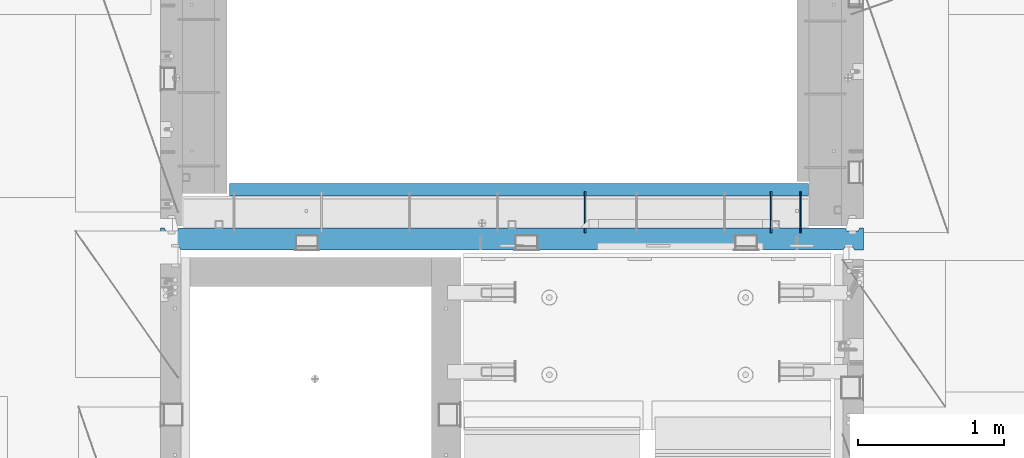
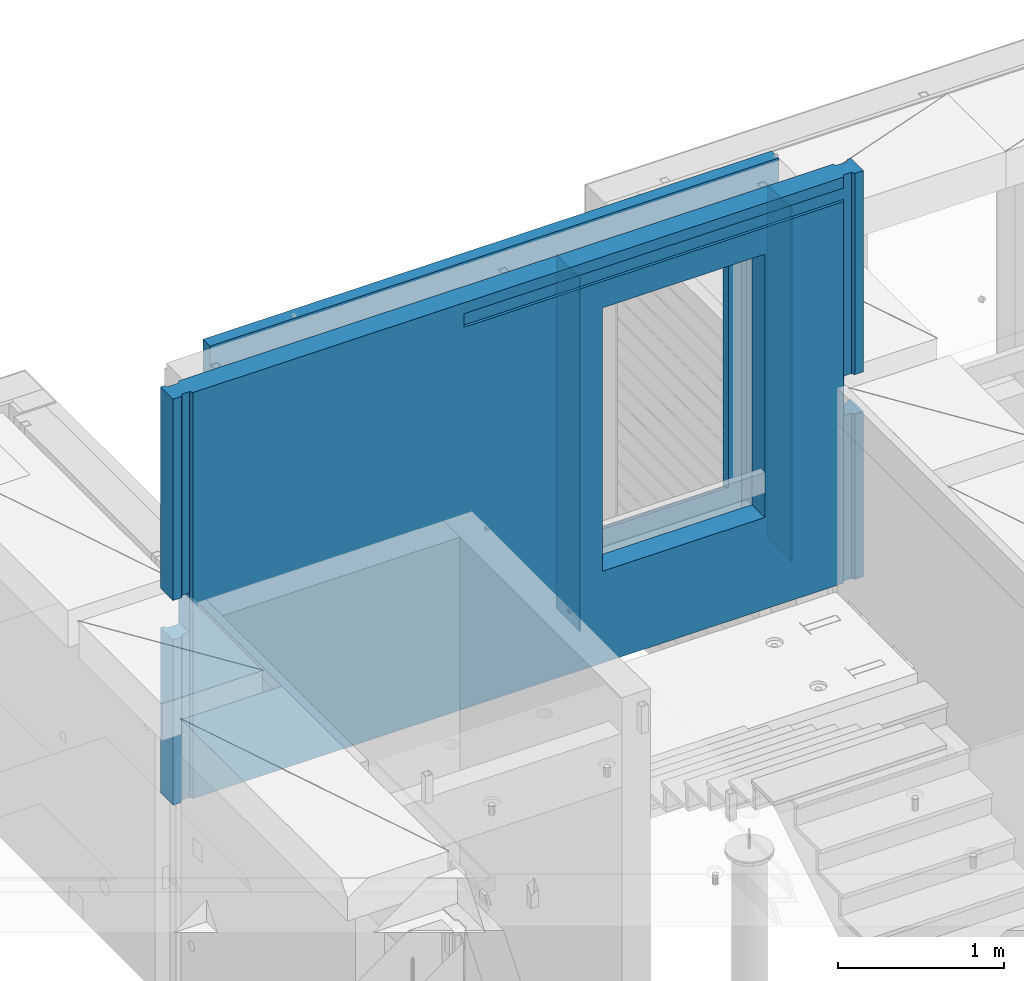
# One storey, part 238 of 349: 5 walls, 1 element without a shape of its own.
"""IFC2X3 building model written with IfcOpenShell, lengths in millimetres."""

from ifc_helpers import new_model, si_unit, frame, origin_with_axes, place, context, subcontext, project, spatial, faceted_brep, material, type_object, element, aggregate, save


model = new_model("IFC2X3")

# Units and contexts
model_context = context("Model", 3, precision=1e-05, world=origin_with_axes())
body_context = subcontext(model_context, "Body", "Model", "MODEL_VIEW")
ifc_project = project(units=[si_unit("LENGTHUNIT", "METRE", prefix="MILLI"), si_unit("AREAUNIT", "SQUARE_METRE"), si_unit("VOLUMEUNIT", "CUBIC_METRE"), si_unit("MASSUNIT", "GRAM", prefix="KILO"), si_unit("TIMEUNIT", "SECOND"), si_unit("PLANEANGLEUNIT", "RADIAN"), si_unit("SOLIDANGLEUNIT", "STERADIAN"), si_unit("THERMODYNAMICTEMPERATUREUNIT", "DEGREE_CELSIUS"), si_unit("LUMINOUSINTENSITYUNIT", "LUMEN")], contexts=[model_context])

# Site, building, storey
site_placement = place(None, origin_with_axes())
site = spatial("IfcSite", under=ifc_project, at=site_placement, CompositionType="ELEMENT")
building_placement = place(site_placement, origin_with_axes())
building = spatial("IfcBuilding", under=site, at=building_placement, CompositionType="ELEMENT")
storey_placement = place(building_placement, origin_with_axes())
storey = spatial("IfcBuildingStorey", under=building, at=storey_placement, Name="4", CompositionType="ELEMENT", Elevation=0.0)

# Assembly, walls
assembly_placement = place(storey_placement, origin_with_axes())
assembly = element("IfcElementAssembly", 1, at=assembly_placement, inside=storey, AssemblyPlace="NOTDEFINED", PredefinedType="REINFORCEMENT_UNIT")
ifc_material_1 = material(Name="Undefined")
wall_type_1 = type_object("IfcWallType", PredefinedType="NOTDEFINED")
wall_1_placement = place(assembly_placement, frame((21980.0002441406, 20550.0, 93745.0), z_axis=(0.0, 0.0, 1.0), x_axis=(0.0, 1.0, 0.0)))
wall_1 = element("IfcWall", 2, at=wall_1_placement, type_object=wall_type_1, material=ifc_material_1, Name="(PD)", context=body_context, shape_type="Brep", body=[
    faceted_brep([(0.0, 5.0, -1300.0), (0.0, 5.0, 1300.0), (280.0, 5.0, 1300.0), (280.0, 5.0, -1300.0), (0.0, -5.0, 1300.0), (280.0, -5.0, 1300.0), (0.0, -5.0, -1300.0), (280.0, -5.0, -1300.0)], [[[0, 1, 2, 3]], [[1, 4, 5, 2]], [[4, 6, 7, 5]], [[6, 0, 3, 7]], [[5, 7, 3, 2]], [[6, 4, 1, 0]]]),
])
wall_2_placement = place(assembly_placement, frame((20510.0002441406, 20550.0, 93745.0), z_axis=(0.0, 0.0, 1.0), x_axis=(0.0, 1.0, 0.0)))
wall_2 = element("IfcWall", 3, at=wall_2_placement, type_object=wall_type_1, material=ifc_material_1, Name="(PD)", context=body_context, shape_type="Brep", body=[
    faceted_brep([(0.0, 5.0, -1300.0), (0.0, 5.0, 1300.0), (280.0, 5.0, 1300.0), (280.0, 5.0, -1300.0), (0.0, -5.0, 1300.0), (280.0, -5.0, 1300.0), (0.0, -5.0, -1300.0), (280.0, -5.0, -1300.0)], [[[0, 1, 2, 3]], [[1, 4, 5, 2]], [[4, 6, 7, 5]], [[6, 0, 3, 7]], [[5, 7, 3, 2]], [[6, 4, 1, 0]]]),
])
wall_3_placement = place(assembly_placement, frame((21780.0002441406, 20550.0, 93745.0), z_axis=(0.0, 0.0, 1.0), x_axis=(0.0, 1.0, 0.0)))
wall_3 = element("IfcWall", 4, at=wall_3_placement, type_object=wall_type_1, material=ifc_material_1, Name="(PD)", context=body_context, shape_type="Brep", body=[
    faceted_brep([(0.0, 5.0, -1300.0), (0.0, 5.0, 1300.0), (280.0, 5.0, 1300.0), (280.0, 5.0, -1300.0), (0.0, -5.0, 1300.0), (280.0, -5.0, 1300.0), (0.0, -5.0, -1300.0), (280.0, -5.0, -1300.0)], [[[0, 1, 2, 3]], [[1, 4, 5, 2]], [[4, 6, 7, 5]], [[6, 0, 3, 7]], [[5, 7, 3, 2]], [[6, 4, 1, 0]]]),
])
ifc_material_2 = material(Name="CONCRETE/C30/37")
wall_type_2 = type_object("IfcWallType", PredefinedType="NOTDEFINED")
wall_4_placement = place(assembly_placement, frame((18080.0, 20842.5, 93747.5), z_axis=(0.0, 0.0, 1.0), x_axis=(1.0, 0.0, 0.0)))
wall_4 = element("IfcWall", 5, at=wall_4_placement, type_object=wall_type_2, material=ifc_material_2, context=body_context, shape_type="Brep", body=[
    faceted_brep([(3955.0, 32.4999992499397, 1344.99999999921), (-3.63797880709171e-12, 32.4999992507037, 1344.99999999926), (-3.63797880709171e-12, 32.4999991127006, 1355.00000040044), (3955.0, 32.4999991119439, 1355.00000040044), (3955.0, 42.4999996032966, 1342.99999994476), (0.0, 42.5, 1342.99999994476), (3955.0, 42.4999992424127, 1206.99999988926), (0.0, 42.5, 1206.99999988925), (3955.0, 32.4999991119475, 1205.00000040044), (0.0, 32.4999991127006, 1205.00000040044), (3955.0, 32.4999992499506, 1194.99999999921), (0.0, 32.4999992507037, 1194.99999999926), (3955.0, 42.4999994790196, 1192.99999994478), (0.0, 42.5, 1192.99999994476), (3955.0, 32.499999111973, 1055.00000040044), (3955.0, 32.4999992499688, 1044.99999999921), (3613.82193430323, 32.4999992499688, 1044.99999999921), (3613.821934287, 32.499999111973, 1055.00000040044), (3955.0, 42.4999994184, 1042.99999994476), (3614.99840497971, 42.4999994684003, 1042.99999994476), (3955.0, 42.4999992424309, 906.999999889245), (3614.99840497971, 42.499999307558, 906.999999889245), (3955.0, 32.4999991119621, 905.000000400425), (3613.821934287, 32.4999991119621, 905.000000400425), (3955.0, 32.4999992499652, 894.9999999992), (3613.82193430323, 32.4999992499652, 894.9999999992), (3955.0, 42.4999993825222, 892.999999944761), (3614.99840497971, 42.499999435604, 892.999999944761), (3955.0, 42.4999992424418, 756.999999889231), (3614.99840497971, 42.4999993075689, 756.999999889231), (3955.0, 32.4999991119766, 755.000000400411), (3613.821934287, 32.4999991119766, 755.000000400411), (3955.0, 32.4999992499797, 744.999999999185), (3613.82193430324, 32.4999992499797, 744.999999999185), (3955.0, 42.4999993588208, 742.999999944746), (3614.99840497971, 42.4999994139398, 742.999999944746), (3955.0, 42.4999992424746, 606.999999889231), (3614.99840497971, 42.499999307598, 606.999999889231), (3955.0, 32.4999991120058, 605.000000400425), (3613.821934287, 32.4999991120058, 605.000000400425), (3955.0, 32.4999992499979, 594.9999999992), (3613.82193430324, 32.4999992499979, 594.9999999992), (3955.0, 42.4999993419697, 592.999999944746), (3614.99840497971, 42.4999993985402, 592.999999944746), (3955.0, 42.4999992424782, 456.99999988926), (3614.99840497971, 42.4999993076017, 456.99999988926), (3955.0, 32.499999112013, 455.00000040044), (3613.821934287, 32.499999112013, 455.00000040044), (3955.0, 32.4999992500161, 444.999999999214), (3613.82193430324, 32.4999992500161, 444.999999999214), (3955.0, 42.4999993293859, 442.999999944775), (3614.99840497971, 42.499999387037, 442.999999944775), (3955.0, 42.4999992424855, 306.999999889245), (3614.99840497971, 42.499999307609, 306.999999889245), (3955.0, 32.4999991120167, 305.000000400425), (3613.82193428701, 32.4999991120167, 305.000000400425), (3955.0, 32.4999992500234, 294.9999999992), (3613.82193430324, 32.4999992500234, 294.9999999992), (3955.0, 42.4999993196434, 292.999999944761), (3614.99840497971, 42.4999993781312, 292.999999944761), (3955.0, 42.4999992425037, 156.999999889245), (3614.99840497971, 42.4999993076235, 156.999999889245), (3955.0, 32.4999991120349, 155.000000400425), (3613.82193428701, 32.4999991120349, 155.000000400425), (3955.0, 32.4999992500379, 144.9999999992), (3613.82193430324, 32.4999992500379, 144.9999999992), (3955.0, 42.4999993118727, 142.999999944761), (3614.99840497971, 42.4999993710298, 142.999999944761), (3955.0, 42.4999992425255, 6.99999988924537), (3614.99840497971, 42.4999993076453, 6.99999988924537), (3955.0, 32.4999991120567, 5.0000004004396), (3613.82193428701, 32.4999991120567, 5.0000004004396), (3955.0, 32.4999992500489, -5.0000000007858), (3613.82193430325, 32.4999992500489, -5.0000000007858), (3955.0, 42.4999993095153, -7.00000005523907), (3614.99840497971, 42.4999993688762, -7.00000005523907), (3955.0, 42.4999992468911, -143.000000110784), (3614.99840497971, 42.4999993116326, -143.000000110784), (3955.0, 32.4999991164223, -144.999999599604), (3613.82193428752, 32.4999991164223, -144.999999599604), (3955.0, 32.4999992544181, -155.000000000829), (3613.82193430376, 32.4999992544181, -155.000000000829), (3955.0, 42.4999993037636, -157.000000055268), (3614.99840497971, 42.4999993636156, -157.000000055268), (3955.0, 42.4999992463599, -293.000000110755), (3614.99840497971, 42.4999993111487, -293.000000110755), (3955.0, 32.4999991158911, -294.999999599575), (3613.82193428746, 32.4999991158911, -294.999999599575), (3955.0, 32.4999992538869, -305.000000000786), (3613.82193430369, 32.4999992538869, -305.000000000786), (3955.0, 42.4999992988232, -307.000000055239), (3614.99840497971, 42.4999993591009, -307.000000055239), (3955.0, 42.4999992458288, -443.000000110755), (3614.99840497971, 42.4999993106612, -443.000000110755), (3955.0, 32.49999911536, -444.999999599575), (3613.8219342874, 32.49999911536, -444.999999599575), (3955.0, 32.4999992533558, -455.0000000008), (3613.82193430363, 32.4999992533558, -455.0000000008), (3955.0, 42.4999992945195, -457.000000055239), (3614.99840497971, 42.4999993551683, -457.000000055239), (3955.0, 42.4999992453049, -593.00000011074), (3614.99840497971, 42.4999993101846, -593.00000011074), (3955.0, 32.4999991148361, -594.99999959956), (3613.82193428733, 32.4999991148361, -594.99999959956), (3955.0, 32.4999992528319, -605.000000000786), (3613.82193430357, 32.4999992528319, -605.000000000786), (3955.0, 42.4999992907105, -607.000000055225), (3614.99840497971, 42.4999993516867, -607.000000055225), (3955.0, 42.4999992447629, -743.000000110755), (3614.99840497971, 42.4999993096899, -743.000000110755), (3955.0, 32.499999114294, -744.999999599575), (3613.82193428727, 32.499999114294, -744.999999599575), (3955.0, 32.4999992522935, -755.0000000008), (3613.82193430351, 32.4999992522935, -755.0000000008), (3955.0, 42.4999992873236, -757.000000055239), (3614.99840497971, 42.4999993485908, -757.000000055239), (0.0, -42.5, -1492.5), (0.0, 42.5, -1492.5), (3955.0, 42.5, -1492.5), (3955.0, -42.5, -1492.5), (0.0, 42.5, -1357.00000005524), (3955.0, 42.5, -1357.00000005524), (0.0, 32.4999992507037, -1355.00000000074), (3955.0, 32.4999992501653, -1355.00000000079), (0.0, 32.4999991127006, -1344.99999959956), (3955.0, 32.4999991121695, -1344.99999959956), (3955.0, 42.4999992426383, -1343.00000011075), (0.0, 42.5, -1343.00000011075), (0.0, 42.5, -1207.00000005524), (3955.0, 42.4999992789635, -1207.00000005522), (0.0, 32.4999992507037, -1205.00000000074), (3955.0, 32.4999992506928, -1205.00000000079), (0.0, 32.4999991127006, -1194.99999959956), (3955.0, 32.499999112697, -1194.99999959956), (3955.0, 42.4999992431658, -1193.00000011074), (0.0, 42.5, -1193.00000011075), (0.0, 42.5, -1057.00000005524), (3955.0, 42.4999992814919, -1057.00000005525), (0.0, 32.4999992507037, -1055.00000000074), (3955.0, 32.4999992512312, -1055.00000000081), (0.0, 32.4999991127006, -1044.99999959956), (3955.0, 32.4999991132318, -1044.99999959959), (3955.0, 42.4999992437006, -1043.00000011077), (0.0, 42.5, -1043.00000011075), (0.0, 42.5, -907.000000055239), (3955.0, 42.4999992842677, -907.000000055225), (0.0, 32.4999992507037, -905.000000000742), (3955.0, 32.499999251766, -905.000000000771), (0.0, 32.4999991127006, -894.99999959956), (3955.0, 32.4999991137665, -894.99999959956), (3955.0, 42.4999992442354, -893.00000011074), (0.0, 42.5, -893.000000110755), (0.0, 32.4999991127006, 1055.00000040044), (0.0, 42.5, 1056.99999988925), (2544.99840497971, 42.4999995125218, 1056.99999988925), (2546.17487567242, 32.499999111973, 1055.00000040044), (0.0, 32.4999992507037, 1044.99999999926), (2546.17487565618, 32.4999992499688, 1044.99999999921), (0.0, 42.5, 1042.99999994476), (2544.99840497971, 42.4999996257466, 1042.99999994476), (0.0, 42.5, 906.999999889245), (2544.99840497971, 42.4999995125145, 906.999999889245), (0.0, 32.4999991127006, 905.00000040044), (2546.17487567242, 32.4999991119621, 905.000000400425), (0.0, 32.4999992507037, 894.999999999258), (2546.17487565618, 32.4999992499652, 894.9999999992), (0.0, 42.5, 892.999999944761), (2544.99840497971, 42.49999960266, 892.999999944761), (0.0, 42.5, 756.999999889245), (2544.99840497971, 42.4999995125218, 756.999999889231), (0.0, 32.4999991127006, 755.00000040044), (2546.17487567242, 32.4999991119766, 755.000000400411), (0.0, 32.4999992507037, 744.999999999258), (2546.17487565618, 32.4999992499797, 744.999999999185), (0.0, 42.5, 742.999999944761), (2544.99840497971, 42.4999995874059, 742.999999944746), (0.0, 42.5, 606.999999889245), (2544.99840497971, 42.4999995125399, 606.999999889231), (3.63797880709171e-12, 32.4999991127006, 605.00000040044), (2546.17487567241, 32.4999991120058, 605.000000400425), (3.63797880709171e-12, 32.4999992507037, 594.999999999258), (2546.17487565618, 32.4999992499979, 594.9999999992), (0.0, 42.5, 592.999999944761), (2544.99840497971, 42.4999995765647, 592.999999944746), (0.0, 42.5, 456.999999889245), (2544.99840497971, 42.4999995125436, 456.99999988926), (0.0, 32.4999991127006, 455.00000040044), (2546.17487567241, 32.499999112013, 455.00000040044), (0.0, 32.4999992507037, 444.999999999258), (2546.17487565617, 32.4999992500161, 444.999999999214), (0.0, 42.5, 442.999999944761), (2544.99840497971, 42.4999995684666, 442.999999944775), (0.0, 42.5, 306.999999889245), (2544.99840497971, 42.4999995125509, 306.999999889245), (-3.63797880709171e-12, 32.4999991127006, 305.00000040044), (2546.17487567241, 32.4999991120167, 305.000000400425), (-3.63797880709171e-12, 32.4999992507037, 294.999999999258), (2546.17487565617, 32.4999992500234, 294.9999999992), (0.0, 42.5, 292.999999944761), (2544.99840497971, 42.4999995621984, 292.999999944761), (0.0, 42.5, 156.999999889245), (2544.99840497971, 42.4999995125581, 156.999999889245), (-3.63797880709171e-12, 32.4999991127006, 155.00000040044), (2546.17487567241, 32.4999991120349, 155.000000400425), (-3.63797880709171e-12, 32.4999992507037, 144.999999999258), (2546.17487565617, 32.4999992500379, 144.9999999992), (0.0, 42.5, 142.999999944761), (2544.99840497971, 42.4999995571998, 142.999999944761), (0.0, 42.5, 6.99999988924537), (2544.99840497971, 42.4999995125763, 6.99999988924537), (0.0, 32.4999991127006, 5.0000004004396), (2546.1748756724, 32.4999991120567, 5.0000004004396), (0.0, 32.4999992507037, -5.00000000074215), (2546.17487565617, 32.4999992500489, -5.0000000007858), (0.0, 42.5, -7.00000005523907), (2544.99840497971, 42.4999995556827, -7.00000005523907), (0.0, 42.5, -143.000000110755), (2544.99840497971, 42.4999995153812, -143.000000110784), (3.63797880709171e-12, 32.4999991127006, -144.99999959956), (2546.17487567189, 32.4999991164223, -144.999999599604), (3.63797880709171e-12, 32.4999992507037, -155.000000000742), (2546.17487565566, 32.4999992544181, -155.000000000829), (0.0, 42.5, -157.000000055239), (2544.99840497971, 42.4999995519793, -157.000000055268), (0.0, 42.5, -293.000000110755), (2544.99840497971, 42.4999995150429, -293.000000110755), (0.0, 32.4999991127006, -294.99999959956), (2546.17487567195, 32.4999991158911, -294.999999599575), (0.0, 32.4999992507037, -305.000000000742), (2546.17487565572, 32.4999992538869, -305.000000000786), (0.0, 42.5, -307.000000055239), (2544.99840497971, 42.4999995487997, -307.000000055239), (0.0, 42.5, -443.000000110755), (2544.99840497971, 42.4999995146973, -443.000000110755), (0.0, 32.4999991127006, -444.99999959956), (2546.17487567201, 32.49999911536, -444.999999599575), (0.0, 32.4999992507037, -455.000000000742), (2546.17487565578, 32.4999992533558, -455.0000000008), (0.0, 42.5, -457.000000055239), (2544.99840497971, 42.4999995460312, -457.000000055239), (0.0, 42.5, -593.000000110755), (2544.99840497971, 42.4999995143626, -593.00000011074), (3.63797880709171e-12, 32.4999991127006, -594.99999959956), (2546.17487567208, 32.4999991148361, -594.99999959956), (3.63797880709171e-12, 32.4999992507037, -605.000000000742), (2546.17487565584, 32.4999992528319, -605.000000000786), (0.0, 42.5, -607.000000055239), (2544.99840497971, 42.4999995435792, -607.000000055225), (0.0, 42.5, -743.000000110755), (2544.99840497971, 42.4999995140133, -743.000000110755), (0.0, 32.4999991127006, -744.99999959956), (2546.17487567214, 32.499999114294, -744.999999599575), (0.0, 32.4999992507037, -755.000000000742), (2546.17487565591, 32.4999992522935, -755.0000000008), (0.0, 42.5, -757.000000055239), (2544.99840497971, 42.4999995414, -757.000000055239), (2544.99840497971, 42.5, -857.5), (3614.99840497971, 42.5, -857.5), (2554.99840497971, -42.5, -807.5), (3604.99840497971, -42.5, -807.5), (0.0, -42.5, 1492.5), (3955.0, -42.5, 1492.5), (2554.99840497971, -42.5, 1082.5), (2554.99840497971, -42.5, 1087.5), (3604.99840497971, -42.5, 1087.5), (3604.99840497971, -42.5, 1082.5), (0.0, 42.5, 1492.5), (3955.0, 42.5, 1492.5), (3955.0, 42.4999992424164, 1356.99999988925), (0.0, 42.5, 1356.99999988925), (3955.0, 42.4999992424455, 1056.99999988925), (2554.99840497971, 42.5, 1082.5), (2544.99840497971, 42.5, 1082.5), (3614.99840497971, 42.4999993075689, 1056.99999988925), (3614.99840497971, 42.5, 1082.5), (3604.99840497971, 42.5, 1082.5)], [[[0, 1, 2, 3]], [[4, 5, 1, 0]], [[6, 7, 5, 4]], [[6, 8, 9, 7]], [[10, 11, 9, 8]], [[12, 13, 11, 10]], [[14, 15, 16, 17]], [[15, 18, 19, 16]], [[18, 20, 21, 19]], [[20, 22, 23, 21]], [[22, 24, 25, 23]], [[24, 26, 27, 25]], [[26, 28, 29, 27]], [[28, 30, 31, 29]], [[30, 32, 33, 31]], [[32, 34, 35, 33]], [[34, 36, 37, 35]], [[36, 38, 39, 37]], [[38, 40, 41, 39]], [[40, 42, 43, 41]], [[42, 44, 45, 43]], [[44, 46, 47, 45]], [[46, 48, 49, 47]], [[48, 50, 51, 49]], [[50, 52, 53, 51]], [[52, 54, 55, 53]], [[54, 56, 57, 55]], [[56, 58, 59, 57]], [[58, 60, 61, 59]], [[60, 62, 63, 61]], [[62, 64, 65, 63]], [[64, 66, 67, 65]], [[66, 68, 69, 67]], [[68, 70, 71, 69]], [[70, 72, 73, 71]], [[72, 74, 75, 73]], [[74, 76, 77, 75]], [[76, 78, 79, 77]], [[78, 80, 81, 79]], [[80, 82, 83, 81]], [[82, 84, 85, 83]], [[84, 86, 87, 85]], [[86, 88, 89, 87]], [[88, 90, 91, 89]], [[90, 92, 93, 91]], [[92, 94, 95, 93]], [[94, 96, 97, 95]], [[96, 98, 99, 97]], [[98, 100, 101, 99]], [[100, 102, 103, 101]], [[102, 104, 105, 103]], [[104, 106, 107, 105]], [[106, 108, 109, 107]], [[108, 110, 111, 109]], [[110, 112, 113, 111]], [[112, 114, 115, 113]], [[116, 117, 118, 119]], [[118, 117, 120, 121]], [[121, 120, 122, 123]], [[123, 122, 124, 125]], [[126, 125, 124, 127]], [[126, 127, 128, 129]], [[129, 128, 130, 131]], [[131, 130, 132, 133]], [[134, 133, 132, 135]], [[134, 135, 136, 137]], [[137, 136, 138, 139]], [[139, 138, 140, 141]], [[142, 141, 140, 143]], [[142, 143, 144, 145]], [[145, 144, 146, 147]], [[147, 146, 148, 149]], [[150, 149, 148, 151]], [[152, 153, 154, 155]], [[156, 152, 155, 157]], [[158, 156, 157, 159]], [[160, 158, 159, 161]], [[162, 160, 161, 163]], [[164, 162, 163, 165]], [[166, 164, 165, 167]], [[168, 166, 167, 169]], [[170, 168, 169, 171]], [[172, 170, 171, 173]], [[174, 172, 173, 175]], [[176, 174, 175, 177]], [[178, 176, 177, 179]], [[180, 178, 179, 181]], [[182, 180, 181, 183]], [[184, 182, 183, 185]], [[186, 184, 185, 187]], [[188, 186, 187, 189]], [[190, 188, 189, 191]], [[192, 190, 191, 193]], [[194, 192, 193, 195]], [[196, 194, 195, 197]], [[198, 196, 197, 199]], [[200, 198, 199, 201]], [[202, 200, 201, 203]], [[204, 202, 203, 205]], [[206, 204, 205, 207]], [[208, 206, 207, 209]], [[210, 208, 209, 211]], [[212, 210, 211, 213]], [[214, 212, 213, 215]], [[216, 214, 215, 217]], [[218, 216, 217, 219]], [[220, 218, 219, 221]], [[222, 220, 221, 223]], [[224, 222, 223, 225]], [[226, 224, 225, 227]], [[228, 226, 227, 229]], [[230, 228, 229, 231]], [[232, 230, 231, 233]], [[234, 232, 233, 235]], [[236, 234, 235, 237]], [[238, 236, 237, 239]], [[240, 238, 239, 241]], [[242, 240, 241, 243]], [[244, 242, 243, 245]], [[246, 244, 245, 247]], [[248, 246, 247, 249]], [[250, 248, 249, 251]], [[252, 250, 251, 253]], [[254, 252, 253, 255]], [[114, 150, 151, 254, 255, 256, 257, 115]], [[256, 258, 259, 257]], [[260, 116, 119, 261], [259, 258, 262, 263, 264, 265]], [[266, 260, 261, 267]], [[266, 267, 268, 269]], [[1, 5, 7, 9, 11, 13, 153, 152, 156, 158, 160, 162, 164, 166, 168, 170, 172, 174, 176, 178, 180, 182, 184, 186, 188, 190, 192, 194, 196, 198, 200, 202, 204, 206, 208, 210, 212, 214, 216, 218, 220, 222, 224, 226, 228, 230, 232, 234, 236, 238, 240, 242, 244, 246, 248, 250, 252, 254, 151, 148, 146, 144, 143, 140, 138, 136, 135, 132, 130, 128, 127, 124, 122, 120, 117, 116, 260, 266, 269, 2]], [[268, 3, 2, 269]], [[267, 261, 119, 118, 121, 123, 125, 126, 129, 131, 133, 134, 137, 139, 141, 142, 145, 147, 149, 150, 114, 112, 110, 108, 106, 104, 102, 100, 98, 96, 94, 92, 90, 88, 86, 84, 82, 80, 78, 76, 74, 72, 70, 68, 66, 64, 62, 60, 58, 56, 54, 52, 50, 48, 46, 44, 42, 40, 38, 36, 34, 32, 30, 28, 26, 24, 22, 20, 18, 15, 14, 270, 12, 10, 8, 6, 4, 0, 3, 268]], [[271, 272, 154, 153, 13, 12, 270, 273, 274, 275]], [[262, 258, 256, 255, 253, 251, 249, 247, 245, 243, 241, 239, 237, 235, 233, 231, 229, 227, 225, 223, 221, 219, 217, 215, 213, 211, 209, 207, 205, 203, 201, 199, 197, 195, 193, 191, 189, 187, 185, 183, 181, 179, 177, 175, 173, 171, 169, 167, 165, 163, 161, 159, 157, 155, 154, 272, 263]], [[271, 275, 274, 264, 263, 272]], [[273, 17, 16, 19, 21, 23, 25, 27, 29, 31, 33, 35, 37, 39, 41, 43, 45, 47, 49, 51, 53, 55, 57, 59, 61, 63, 65, 67, 69, 71, 73, 75, 77, 79, 81, 83, 85, 87, 89, 91, 93, 95, 97, 99, 101, 103, 105, 107, 109, 111, 113, 115, 257, 259, 265, 264, 274]], [[270, 14, 17, 273]]]),
])
ifc_material_3 = material(Name="CONCRETE/C25/30")
wall_type_3 = type_object("IfcWallType", PredefinedType="NOTDEFINED")
wall_5_placement = place(assembly_placement, frame((17610.0, 20505.0, 93747.5), z_axis=(0.0, 0.0, 1.0), x_axis=(1.0, 0.0, 0.0)))
wall_5 = element("IfcWall", 6, at=wall_5_placement, type_object=wall_type_3, material=ifc_material_3, context=body_context, shape_type="Brep", body=[
    faceted_brep([(115.000000752763, 54.9999994575555, -277.499999999956), (35.0000012841592, 54.9999974671882, -277.499999999956), (25.0000034119694, 75.0, -277.499999999956), (0.0, 75.0, -277.499999999956), (0.0, -75.0, -277.499999999956), (59.9999958419066, -75.0, -277.499999999956), (73.0000021298038, -54.9999990274482, -277.499999999956), (125.000000000065, -54.9999987501142, -277.499999999956), (124.999999335741, 75.0, -277.499999999956), (125.000000000065, 74.9999996833285, 12.5000000000582), (125.000000000065, -54.9999987501142, 12.5000000000582), (73.0000021298038, -54.9999990274482, 12.5000000000437), (59.9999958419066, -75.0, 12.5000000000437), (0.0, -75.0, 12.5000000000437), (0.0, 75.0, 12.5000000000437), (25.0000034119694, 75.0, 12.5000000000437), (35.0000012841592, 54.9999974671882, 12.5000000000437), (115.000000752763, 54.9999994575555, 12.5000000000582), (4684.99999994252, 55.0000001373264, 1492.5), (4765.0000011171, 55.0000001731059, 1492.5), (4765.0000011171, 55.0000001731059, 12.5000000000582), (4684.99999994252, 55.0000001373264, 12.5000000000437), (2023.0, -55.0, 1412.5), (2023.0, -55.0, 1312.5), (4673.0, -55.0, 1312.5), (4673.0, -55.0, 1412.5), (4659.9999958419, -75.0, 1492.5), (4659.9999958419, -75.0, 1412.5), (4672.99999996855, -54.9999999109459, 1492.5), (2023.0, -75.0, 1412.5), (2023.0, -75.0, 1312.5), (4659.9999958419, -75.0, 1312.5), (4659.9999958419, -75.0, -1492.5), (4672.99999996855, -54.9999999109459, -1492.5), (4726.9999998731, -54.9999987450756, -1492.5), (4740.00000278436, -75.0, -1492.5), (4740.00000278436, -75.0000009276337, -277.499999999956), (4726.9999998731, -54.9999987450756, -277.499999999956), (4684.99999994252, 55.0000001373264, -1492.5), (4675.0, 75.0, -1492.5), (4675.0, 75.0, -277.499999999956), (4684.99999994252, 55.0000001373264, -277.499999999956), (4765.0000011171, 55.0000001731059, -1492.5), (4765.0000011171, 55.0000001731059, -277.499999999956), (4774.99999933574, 75.0, -1492.5), (4774.99999933574, 75.0000000182044, -277.499999999956), (4800.0, 75.0, -1492.5), (4800.0, 75.0, -277.499999999956), (4800.0, -75.0, -1492.5), (4800.0, -75.0, -277.499999999956), (4674.9999998891, -54.9999999110878, -277.499999999956), (4675.0, 75.0, 12.5000000000437), (4675.00000000007, -54.9999999110878, 12.5000000000437), (4726.9999998731, -54.9999987450756, 1492.5), (4726.9999998731, -54.9999987450756, 12.5000000000582), (4740.00000278436, -75.0000022790009, 1492.5), (4740.00000278436, -75.0000011490447, 12.5000000000582), (4800.0, -75.0, 1492.5), (4800.0, -75.0, 12.5000000000582), (4800.0, 75.0, 1492.5), (4800.00000000007, 74.9999996833285, 12.5000000000582), (4774.99999933574, 75.0000000447253, 1492.5), (4774.99999933574, 75.0000000225482, 12.5000000000582), (4675.0, 75.0, 1492.5), (35.0000012841592, 54.9999974671882, 1492.5), (25.0000034119694, 75.0, 1492.5), (0.0, 75.0, 1492.5), (0.0, -75.0, 1492.5), (59.9999958419066, -75.0, 1492.5), (73.0000021298038, -54.9999990274482, 1492.5), (126.999999875414, -54.9999987394476, 1492.5), (140.000002784363, -75.0, 1492.5), (124.999999335741, 75.0, 1492.5), (115.000000752763, 54.9999994575555, 1492.5), (73.0000021298038, -54.9999990274482, -1492.5), (126.999999875414, -54.9999987394476, -1492.5), (59.9999958419066, -75.0, -1492.5), (0.0, -75.0, -1492.5), (0.0, 75.0, -1492.5), (25.0000034119694, 75.0, -1492.5), (35.0000012841592, 54.9999974671882, -1492.5), (115.000000752763, 54.9999994575555, -1492.5), (124.999999335741, 75.0, -1492.5), (140.000002784363, -75.0, -1492.5), (2984.99840497971, -75.0000022790045, -817.5), (2984.99840497971, -75.0000022790045, 1117.5), (4114.99840497971, -75.0000022790045, 1117.5), (4114.99840497971, -75.0000022790045, -817.5), (2989.05245909535, 75.0, 1113.44594588435), (2989.05245909535, 75.0, -813.445945884348), (4110.94435086406, 75.0, -813.445945884348), (4110.94435086406, 75.0, 1113.44594588435)], [[[0, 1, 2, 3, 4, 5, 6, 7, 8]], [[9, 10, 11, 12, 13, 14, 15, 16, 17]], [[8, 7, 10, 9]], [[18, 19, 20, 21]], [[22, 23, 24, 25]], [[26, 27, 25, 28]], [[29, 22, 25, 27]], [[30, 23, 22, 29]], [[23, 30, 31, 24]], [[31, 32, 33, 24]], [[34, 35, 36, 37]], [[38, 39, 40, 41]], [[42, 38, 41, 43]], [[44, 42, 43, 45]], [[46, 44, 45, 47]], [[48, 46, 47, 49]], [[35, 48, 49, 36]], [[47, 45, 43, 41, 40, 50, 37, 36, 49]], [[51, 52, 50, 40]], [[53, 28, 25, 24, 33, 34, 37, 50, 52, 54]], [[55, 53, 54, 56]], [[57, 55, 56, 58]], [[59, 57, 58, 60]], [[61, 59, 60, 62]], [[19, 61, 62, 20]], [[60, 58, 56, 54, 52, 51, 21, 20, 62]], [[63, 18, 21, 51]], [[64, 65, 66, 67, 68, 69, 70, 71, 26, 28, 53, 55, 57, 59, 61, 19, 18, 63, 72, 73]], [[73, 72, 9, 17]], [[64, 73, 17, 16]], [[65, 64, 16, 15]], [[66, 65, 15, 14]], [[67, 66, 14, 13]], [[68, 67, 13, 12]], [[69, 68, 12, 11]], [[6, 74, 75, 70, 69, 11, 10, 7]], [[76, 74, 6, 5]], [[77, 76, 5, 4]], [[78, 77, 4, 3]], [[79, 78, 3, 2]], [[80, 79, 2, 1]], [[81, 80, 1, 0]], [[82, 81, 0, 8]], [[39, 38, 42, 44, 46, 48, 35, 34, 33, 32, 83, 75, 74, 76, 77, 78, 79, 80, 81, 82]], [[71, 70, 75, 83]], [[32, 31, 30, 29, 27, 26, 71, 83], [84, 85, 86, 87]], [[88, 85, 84, 89]], [[87, 90, 89, 84]], [[86, 91, 90, 87]], [[85, 88, 91, 86]], [[72, 63, 51, 40, 39, 82, 8, 9], [89, 90, 91, 88]]]),
])
aggregate(assembly, [wall_4, wall_1, wall_2, wall_3, wall_5])

save(model, "model.ifc")
